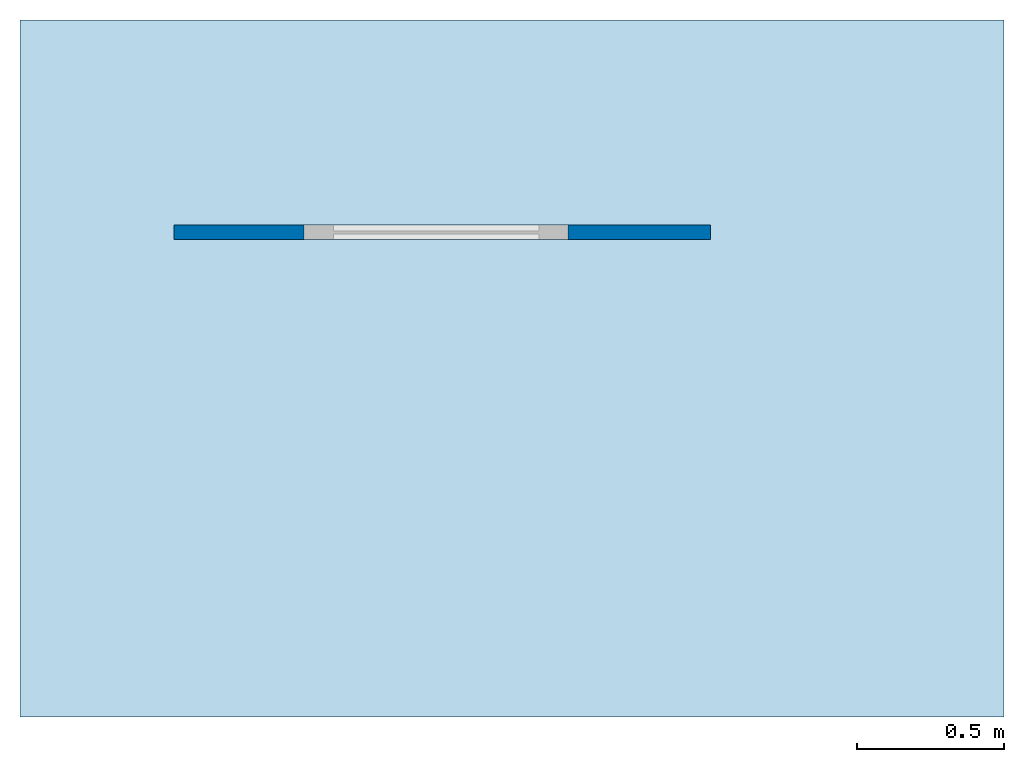
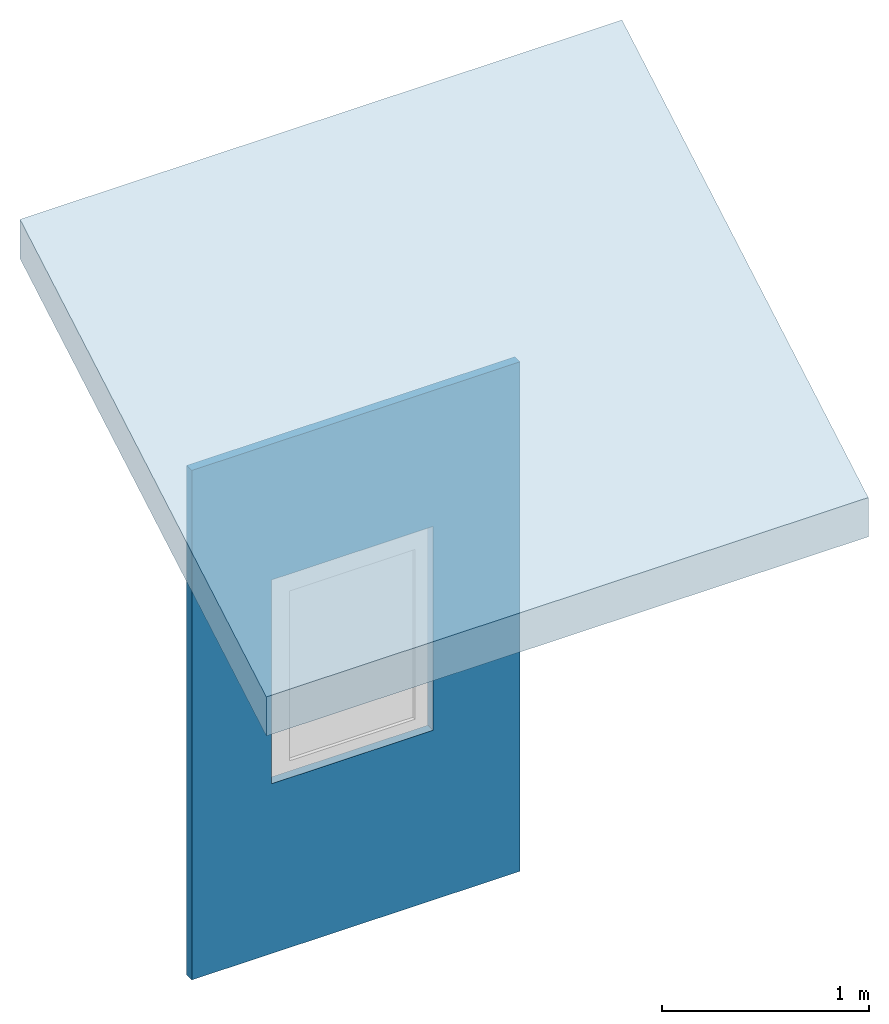
# One storey, part 1 of 2: 1 slab, 1 wall, 1 opening.
"""IFC4 building model written with IfcOpenShell, lengths in feet."""

from ifc_helpers import new_model, entity, si_unit, converted_unit, frame, origin_with_axes, origin_2d_with_axis, place, context, subcontext, project, spatial, line, indexed_curve, outline, extrude, source, transform, mapped, material, layer, layer_set, layer_usage, type_object, element, save


model = new_model("IFC4")

# Units and contexts
model_context = context("Model", 3, precision=1e-05, world=origin_with_axes())
plan_context = context("Plan", 2, precision=1e-05, world=origin_2d_with_axis())
body_context = subcontext(model_context, "Body", "Model", "MODEL_VIEW")
ifc_project = project(units=[converted_unit("PLANEANGLEUNIT", "degree", entity("IfcReal", 0.0174532925199433), si_unit("PLANEANGLEUNIT", "RADIAN"), dimensions=[0, 0, 0, 0, 0, 0, 0]), converted_unit("LENGTHUNIT", "foot", entity("IfcReal", 0.3048), si_unit("LENGTHUNIT", "METRE"), dimensions=[1, 0, 0, 0, 0, 0, 0]), converted_unit("VOLUMEUNIT", "cubic foot", entity("IfcReal", 0.0283168467116885), si_unit("VOLUMEUNIT", "CUBIC_METRE"), dimensions=[3, 0, 0, 0, 0, 0, 0]), converted_unit("AREAUNIT", "square foot", entity("IfcReal", 0.09290304), si_unit("AREAUNIT", "SQUARE_METRE"), dimensions=[2, 0, 0, 0, 0, 0, 0])], contexts=[model_context, plan_context])

# Site, building, storey
site_placement = place(None, origin_with_axes())
site = spatial("IfcSite", under=ifc_project, at=site_placement)
building_placement = place(site_placement, origin_with_axes())
building = spatial("IfcBuilding", under=site, at=building_placement, Name="Building")
storey_placement = place(building_placement, origin_with_axes())
storey = spatial("IfcBuildingStorey", under=building, at=storey_placement, Name="Storey")

# Slab
ifc_material = material()
ifc_layer_1 = layer(ifc_material, 0.656167979002625)
ifc_layer_set_1 = layer_set([ifc_layer_1])
ifc_layer_usage_1 = layer_usage(ifc_layer_set_1, "AXIS3", "POSITIVE", 0.0)
slab_type = type_object("IfcSlabType", Name="FLR200", PredefinedType="NOTDEFINED", material=ifc_layer_set_1)
slab_placement = place(storey_placement, frame((-1.72072997086943, 2.45630271791473, 13.0498909887679), z_axis=(0.0, -0.500000121947118, 0.866025333378226), x_axis=(1.0, 0.0, 0.0)))
element("IfcSlab", 1, at=slab_placement, inside=storey, type_object=slab_type, material=ifc_layer_usage_1, Name="Slab", context=body_context, shape_type="SweptSolid", body=[
    extrude(outline(indexed_curve([(0.0, 0.0), (10.9999996470654, 0.0), (10.9999988648522, -8.99999942679418), (1.11465379009097e-05, -9.00000020900736), (0.0, 0.0)])), None, (0.0, 0.500000012618391, 0.866025396499207), 0.757677524995337),
])

# Wall, opening
ifc_layer_2 = layer(ifc_material, 0.164041994750656)
ifc_layer_set_2 = layer_set([ifc_layer_2])
ifc_layer_usage_2 = layer_usage(ifc_layer_set_2, "AXIS2", "POSITIVE", 0.0)
wall_type = type_object("IfcWallType", Name="WAL50", PredefinedType="NOTDEFINED", material=ifc_layer_set_2)
wall_placement = place(storey_placement, origin_with_axes())
wall = element("IfcWall", 2, at=wall_placement, inside=storey, type_object=wall_type, material=ifc_layer_usage_2, Name="Wall", context=body_context, shape_type="SweptSolid", body=[
    extrude(outline(indexed_curve([(0.0, 0.0), (0.0, 0.164041994750656), (5.99999993108804, 0.164041994750656), (5.99999993108804, 0.0), (0.0, 0.0)], self_intersect=False)), origin_with_axes(), (0.0, 0.0, 1.0), 9.84251968503937),
])
shared_shape = source(origin_with_axes(), body_context, "Body", "SweptSolid", [
    extrude(outline(indexed_curve([(0.0, 0.0), (2.95275592803955, 0.0), (2.95275592803955, 3.93700814247131), (0.0, 3.93700814247131)], segments=[line(1, 2, 3, 4, 1)])), frame((0.0, -1.96850395202637, 0.0), z_axis=(0.0, -1.0, 0.0), x_axis=(1.0, 0.0, 0.0)), (0.0, 0.0, -1.0), 3.93700787401575),
])
opening_placement = place(wall_placement, frame((1.45374926838662, 0.0, 3.28083989501312), z_axis=(0.0, 0.0, 1.0), x_axis=(1.0, 0.0, 0.0)))
element("IfcOpeningElement", 3, at=opening_placement, cuts=wall, Name="Opening", PredefinedType="OPENING", context=body_context, shape_type="MappedRepresentation", body=[
    mapped(shared_shape, transform((0.0, 0.0, 0.0), x_axis=(1.0, 0.0, 0.0), y_axis=(0.0, 1.0, 0.0), z_axis=(0.0, 0.0, 1.0), scale=1.0)),
])

save(model, "model.ifc")
